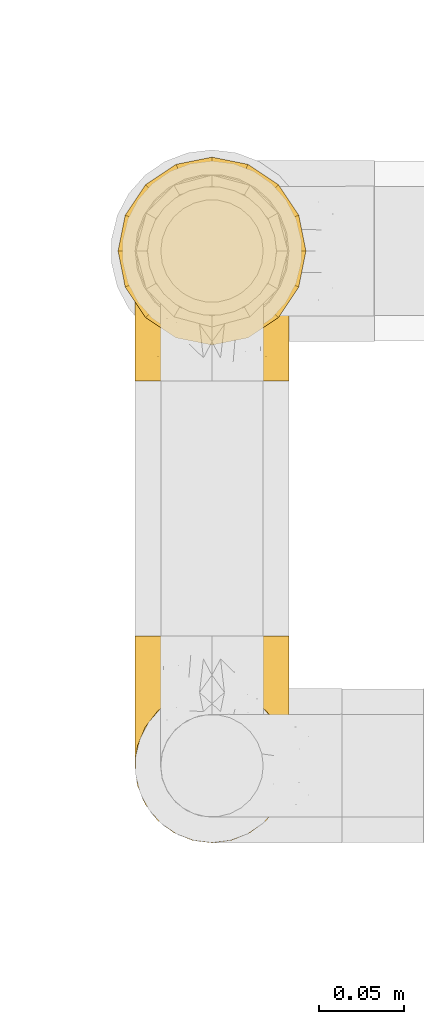
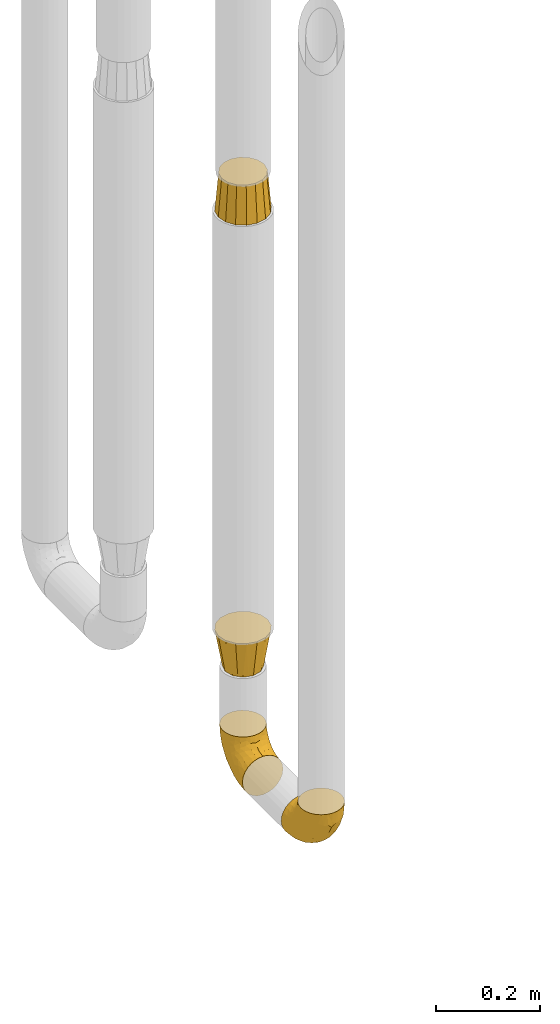
# One storey, part 108 of 827: 4 coverings.
"""IFC2X3 building model written with IfcOpenShell, lengths in millimetres."""

from ifc_helpers import new_model, entity, si_unit, converted_unit, derived_unit, direction, frame, origin, place, context, subcontext, project, spatial, faceted_brep, element, save


model = new_model("IFC2X3")

# Units and contexts
model_context = context("Model", 3, precision=0.01, world=origin(), true_north=direction((6.12303176911189e-17, 1.0)))
body_context = subcontext(model_context, "Body", "Model", "MODEL_VIEW")
ifc_project = project(units=[si_unit("LENGTHUNIT", "METRE", prefix="MILLI"), si_unit("AREAUNIT", "SQUARE_METRE"), si_unit("VOLUMEUNIT", "CUBIC_METRE"), converted_unit("PLANEANGLEUNIT", "DEGREE", entity("IfcRatioMeasure", 0.0174532925199433), si_unit("PLANEANGLEUNIT", "RADIAN"), dimensions=[0, 0, 0, 0, 0, 0, 0]), si_unit("MASSUNIT", "GRAM", prefix="KILO"), derived_unit("MASSDENSITYUNIT", [(si_unit("MASSUNIT", "GRAM", prefix="KILO"), 1), (si_unit("LENGTHUNIT", "METRE"), -3)]), derived_unit("MOMENTOFINERTIAUNIT", [(si_unit("LENGTHUNIT", "METRE"), 4)]), si_unit("TIMEUNIT", "SECOND"), si_unit("FREQUENCYUNIT", "HERTZ"), si_unit("THERMODYNAMICTEMPERATUREUNIT", "DEGREE_CELSIUS"), derived_unit("THERMALTRANSMITTANCEUNIT", [(si_unit("MASSUNIT", "GRAM", prefix="KILO"), 1), (si_unit("THERMODYNAMICTEMPERATUREUNIT", "KELVIN"), -1), (si_unit("TIMEUNIT", "SECOND"), -3)]), derived_unit("VOLUMETRICFLOWRATEUNIT", [(si_unit("LENGTHUNIT", "METRE"), 3), (si_unit("TIMEUNIT", "SECOND"), -1)]), derived_unit("MASSFLOWRATEUNIT", [(si_unit("MASSUNIT", "GRAM", prefix="KILO"), 1), (si_unit("TIMEUNIT", "SECOND"), -1)]), derived_unit("ROTATIONALFREQUENCYUNIT", [(si_unit("TIMEUNIT", "SECOND"), -1)]), si_unit("ELECTRICCURRENTUNIT", "AMPERE"), si_unit("ELECTRICVOLTAGEUNIT", "VOLT"), si_unit("POWERUNIT", "WATT"), si_unit("FORCEUNIT", "NEWTON", prefix="KILO"), si_unit("ILLUMINANCEUNIT", "LUX"), si_unit("LUMINOUSFLUXUNIT", "LUMEN"), si_unit("LUMINOUSINTENSITYUNIT", "CANDELA"), derived_unit("USERDEFINED", [(si_unit("MASSUNIT", "GRAM", prefix="KILO"), -1), (si_unit("LENGTHUNIT", "METRE"), -2), (si_unit("TIMEUNIT", "SECOND"), 3), (si_unit("LUMINOUSFLUXUNIT", "LUMEN"), 1)]), derived_unit("LINEARVELOCITYUNIT", [(si_unit("LENGTHUNIT", "METRE"), 1), (si_unit("TIMEUNIT", "SECOND"), -1)]), si_unit("PRESSUREUNIT", "PASCAL"), derived_unit("USERDEFINED", [(si_unit("LENGTHUNIT", "METRE"), -2), (si_unit("MASSUNIT", "GRAM", prefix="KILO"), 1), (si_unit("TIMEUNIT", "SECOND"), -2)]), derived_unit("LINEARFORCEUNIT", [(si_unit("MASSUNIT", "GRAM", prefix="KILO"), 1), (si_unit("LENGTHUNIT", "METRE"), 1), (si_unit("TIMEUNIT", "SECOND"), -2), (si_unit("LENGTHUNIT", "METRE"), -1)]), derived_unit("PLANARFORCEUNIT", [(si_unit("MASSUNIT", "GRAM", prefix="KILO"), 1), (si_unit("LENGTHUNIT", "METRE"), 1), (si_unit("TIMEUNIT", "SECOND"), -2), (si_unit("LENGTHUNIT", "METRE"), -2)])], contexts=[model_context])

# Site, building, storey
site_placement = place(None, origin())
site = spatial("IfcSite", under=ifc_project, at=site_placement, CompositionType="ELEMENT")
building_placement = place(site_placement, origin())
building = spatial("IfcBuilding", under=site, at=building_placement, CompositionType="ELEMENT")
storey_placement = place(building_placement, frame((0.0, 0.0, 28200.0)))
storey = spatial("IfcBuildingStorey", under=building, at=storey_placement, Name="08", CompositionType="ELEMENT", Elevation=28200.0)

# Coverings
covering_1_placement = place(storey_placement, frame((21053.55, 10451.58, 311.51)))
element("IfcCovering", 1, at=covering_1_placement, inside=storey, Name=":ADSK_", ObjectType=":ADSK_", PredefinedType="INSULATION", context=body_context, shape_type="Brep", body=[
    faceted_brep([(90.76, 122.75, 36.69), (87.42, 122.75, 27.15), (82.04, 122.75, 18.59), (74.89, 122.75, 11.44), (66.33, 122.75, 6.06), (56.79, 122.75, 2.73), (46.75, 122.75, 1.6), (36.69, 122.75, 2.73), (27.15, 122.75, 6.07), (18.59, 122.75, 11.45), (11.44, 122.75, 18.6), (6.06, 122.75, 27.16), (2.73, 122.75, 36.7), (1.6, 122.75, 46.75), (2.73, 122.75, 56.8), (6.07, 122.75, 66.34), (11.45, 122.75, 74.9), (18.6, 122.75, 82.05), (27.16, 122.75, 87.43), (36.7, 122.75, 90.76), (46.75, 122.75, 91.9), (56.8, 122.75, 90.76), (66.34, 122.75, 87.42), (74.9, 122.75, 82.04), (82.05, 122.75, 74.89), (87.43, 122.75, 66.33), (90.76, 122.75, 56.79), (91.9, 122.75, 46.75), (35.06, 90.36, 122.75), (24.17, 85.85, 122.75), (14.82, 78.67, 122.75), (7.64, 69.32, 122.75), (3.13, 58.43, 122.75), (1.6, 46.75, 122.75), (3.13, 35.06, 122.75), (7.64, 24.17, 122.75), (14.82, 14.82, 122.75), (24.17, 7.64, 122.75), (35.06, 3.13, 122.75), (46.75, 1.6, 122.75), (58.43, 3.13, 122.75), (69.32, 7.64, 122.75), (78.67, 14.82, 122.75), (85.85, 24.17, 122.75), (90.36, 35.06, 122.75), (91.9, 46.75, 122.75), (90.36, 58.43, 122.75), (85.85, 69.32, 122.75), (78.67, 78.67, 122.75), (69.32, 85.85, 122.75), (58.43, 90.36, 122.75), (46.75, 91.9, 122.75), (46.75, 51.54, 24.73), (55.2, 47.17, 29.08), (46.75, 38.13, 38.13), (46.75, 7.52, 85.31), (54.53, 5.85, 93.59), (46.75, 5.11, 100.54), (59.63, 19.2, 63.54), (62.07, 38.98, 38.98), (71.86, 35.02, 50.71), (62.65, 8.21, 93.33), (71.33, 19.28, 75.2), (72.93, 12.19, 100.46), (91.2, 101.39, 41.6), (86.31, 34.43, 80.86), (80.89, 20.95, 94.87), (79.49, 30.74, 67.96), (90.68, 72.93, 52.16), (86.84, 56.64, 52.1), (87.38, 80.81, 36.74), (76.87, 93.43, 17.11), (83.73, 100.76, 23.24), (81.03, 74.27, 29.18), (91.9, 93.66, 52.53), (91.9, 81.33, 60.77), (91.9, 69.01, 69.01), (91.03, 40.87, 100.68), (87.58, 29.38, 103.79), (56.52, 67.05, 16.37), (46.75, 85.31, 7.52), (60.4, 93.68, 7.31), (91.9, 52.53, 93.66), (91.9, 50.71, 102.83), (91.9, 48.88, 112.01), (67.87, 72.77, 18.17), (90.35, 51.21, 71.97), (69.57, 101.18, 9.83), (46.75, 100.54, 5.11), (79.91, 48.74, 45.97), (91.9, 112.01, 48.88), (91.9, 102.83, 50.71), (74.99, 73.88, 22.83), (46.75, 24.73, 51.54), (91.9, 60.77, 81.33), (88.53, 103.08, 31.74), (72.65, 54.8, 32.48), (46.75, 16.13, 68.42), (62.97, 55.92, 25.33), (46.75, 68.42, 16.13), (66.2, 104.98, 92.29), (56.6, 108.58, 94.12), (59.89, 98.21, 100.97), (90.95, 61.56, 95.91), (90.22, 60.69, 107.9), (76.64, 100.0, 87.24), (71.58, 95.88, 95.46), (79.99, 90.81, 90.41), (89.54, 84.88, 74.17), (89.97, 73.29, 83.77), (81.32, 113.4, 76.72), (74.56, 109.8, 84.44), (84.15, 102.13, 76.42), (90.37, 67.29, 90.07), (87.82, 70.34, 99.69), (90.98, 95.15, 61.74), (90.96, 105.49, 58.16), (85.14, 71.5, 112.6), (58.11, 92.87, 110.45), (46.75, 96.03, 107.32), (78.39, 81.34, 108.48), (88.22, 107.44, 66.63), (66.06, 88.36, 115.23), (68.6, 90.43, 105.79), (63.78, 114.37, 89.6), (88.42, 98.41, 69.39), (90.61, 88.73, 66.99), (83.8, 76.89, 102.31), (77.98, 86.08, 99.54), (91.22, 112.64, 55.27), (83.46, 94.21, 82.03), (46.75, 112.22, 94.71), (46.75, 107.32, 96.03), (84.66, 79.95, 94.11), (86.33, 84.51, 84.21), (46.75, 101.67, 101.67), (46.75, 94.71, 112.22), (15.1, 81.34, 108.48), (9.69, 76.89, 102.31), (15.52, 86.08, 99.54), (8.83, 79.96, 94.11), (35.39, 92.87, 110.46), (12.18, 113.41, 76.74), (1.6, 102.83, 50.71), (2.53, 105.5, 58.17), (2.27, 112.64, 55.27), (36.9, 108.58, 94.12), (27.31, 104.98, 92.3), (33.62, 98.2, 100.98), (5.07, 98.4, 69.41), (9.36, 102.13, 76.44), (5.27, 107.44, 66.65), (27.43, 88.36, 115.24), (1.6, 50.71, 102.83), (1.6, 48.88, 112.01), (10.05, 94.22, 82.05), (16.87, 100.01, 87.25), (8.35, 71.5, 112.6), (3.27, 60.69, 107.9), (1.6, 52.53, 93.66), (21.94, 95.89, 95.48), (29.72, 114.37, 89.6), (1.6, 81.33, 60.77), (1.6, 69.01, 69.01), (3.96, 84.88, 74.17), (1.6, 112.01, 48.88), (18.95, 109.8, 84.45), (2.54, 61.56, 95.91), (3.12, 67.29, 90.07), (1.6, 60.77, 81.33), (2.51, 95.14, 61.75), (3.52, 73.29, 83.77), (7.17, 84.53, 84.21), (1.6, 93.66, 52.53), (13.52, 90.82, 90.42), (2.88, 88.73, 67.0), (5.67, 70.34, 99.69), (24.89, 90.43, 105.8), (12.6, 20.95, 94.87), (7.18, 34.43, 80.86), (14.0, 30.74, 67.95), (22.16, 19.29, 75.17), (21.61, 35.07, 50.65), (3.14, 51.21, 71.97), (6.65, 56.67, 52.08), (20.82, 54.85, 32.46), (31.41, 38.98, 38.98), (5.91, 29.38, 103.79), (2.46, 40.87, 100.68), (33.87, 19.2, 63.54), (30.84, 8.21, 93.32), (38.96, 5.85, 93.59), (20.56, 12.19, 100.44), (2.81, 72.93, 52.17), (6.1, 80.83, 36.75), (2.29, 101.39, 41.61), (33.08, 93.69, 7.31), (16.61, 93.43, 17.12), (36.96, 67.04, 16.37), (9.75, 100.76, 23.26), (25.61, 72.78, 18.17), (30.5, 55.93, 25.33), (23.91, 101.18, 9.84), (12.45, 74.27, 29.19), (18.49, 73.89, 22.84), (4.96, 103.09, 31.75), (13.56, 48.78, 45.96), (38.28, 47.19, 29.07)], [[[0, 1, 2, 3, 4, 5, 6, 7, 8, 9, 10, 11, 12, 13, 14, 15, 16, 17, 18, 19, 20, 21, 22, 23, 24, 25, 26, 27]], [[28, 29, 30, 31, 32, 33, 34, 35, 36, 37, 38, 39, 40, 41, 42, 43, 44, 45, 46, 47, 48, 49, 50, 51]], [[52, 53, 54]], [[55, 56, 57]], [[58, 59, 60]], [[61, 62, 63]], [[27, 64, 0]], [[65, 66, 67]], [[41, 40, 61]], [[68, 69, 70]], [[66, 43, 42]], [[63, 42, 41]], [[71, 72, 73]], [[72, 2, 1]], [[68, 74, 75, 76]], [[45, 44, 77]], [[43, 78, 44]], [[79, 80, 81]], [[77, 82, 83, 84, 45]], [[79, 81, 85]], [[71, 2, 72]], [[65, 86, 77]], [[4, 81, 5]], [[66, 65, 78]], [[4, 3, 87]], [[81, 88, 5]], [[63, 66, 42]], [[68, 70, 64]], [[67, 60, 89]], [[71, 3, 2]], [[64, 27, 90, 91, 74]], [[92, 71, 73]], [[40, 57, 56]], [[59, 93, 54]], [[86, 76, 94, 82]], [[1, 0, 95]], [[58, 62, 61]], [[60, 96, 89]], [[85, 81, 87]], [[56, 97, 58]], [[65, 67, 69]], [[87, 81, 4]], [[67, 89, 69]], [[61, 63, 41]], [[95, 72, 1]], [[73, 72, 70]], [[69, 73, 70]], [[73, 89, 96]], [[3, 71, 87]], [[85, 87, 71]], [[58, 61, 56]], [[59, 58, 93]], [[76, 86, 68]], [[69, 89, 73]], [[68, 86, 69]], [[65, 69, 86]], [[68, 64, 74]], [[95, 64, 70]], [[98, 79, 85]], [[79, 52, 99, 80]], [[66, 62, 67]], [[62, 58, 60]], [[62, 60, 67]], [[59, 98, 96]], [[59, 96, 60]], [[96, 85, 92]], [[88, 81, 80]], [[88, 6, 5]], [[66, 63, 62]], [[64, 95, 0]], [[72, 95, 70]], [[77, 44, 78]], [[86, 82, 77]], [[40, 39, 57]], [[96, 98, 85]], [[40, 56, 61]], [[66, 78, 43]], [[77, 78, 65]], [[79, 98, 53]], [[96, 92, 73]], [[85, 71, 92]], [[97, 56, 55]], [[97, 93, 58]], [[53, 98, 59]], [[54, 53, 59]], [[79, 53, 52]], [[100, 101, 102]], [[46, 45, 84, 83]], [[103, 104, 82]], [[82, 104, 83]], [[105, 106, 107]], [[108, 109, 76]], [[110, 111, 112]], [[103, 113, 114]], [[115, 74, 116]], [[48, 47, 117]], [[118, 102, 119]], [[49, 48, 120]], [[74, 91, 116]], [[116, 121, 115]], [[49, 122, 50]], [[123, 106, 102]], [[124, 111, 22]], [[125, 126, 115]], [[23, 22, 111]], [[24, 110, 121]], [[120, 127, 128]], [[90, 26, 129]], [[27, 26, 90]], [[121, 125, 115]], [[24, 121, 25]], [[130, 105, 107]], [[129, 25, 116]], [[21, 20, 131]], [[120, 123, 122]], [[112, 105, 130]], [[50, 118, 51]], [[21, 124, 22]], [[101, 131, 132]], [[117, 120, 48]], [[24, 23, 110]], [[127, 114, 133]], [[75, 108, 76]], [[107, 134, 130]], [[133, 114, 113]], [[129, 116, 91]], [[25, 121, 116]], [[121, 112, 125]], [[75, 74, 115]], [[101, 135, 102]], [[131, 101, 21]], [[101, 100, 124]], [[128, 127, 133]], [[119, 136, 51, 118]], [[104, 47, 46]], [[83, 104, 46]], [[117, 104, 114]], [[101, 124, 21]], [[111, 124, 100]], [[102, 118, 123]], [[133, 134, 107]], [[111, 110, 23]], [[114, 104, 103]], [[94, 76, 109]], [[121, 110, 112]], [[122, 118, 50]], [[134, 109, 108]], [[133, 107, 128]], [[112, 108, 125]], [[126, 125, 108]], [[108, 75, 126]], [[75, 115, 126]], [[109, 134, 133]], [[130, 108, 112]], [[108, 130, 134]], [[105, 112, 111]], [[111, 100, 105]], [[106, 105, 100]], [[102, 106, 100]], [[128, 106, 123]], [[90, 129, 91]], [[25, 129, 26]], [[104, 117, 47]], [[117, 114, 127]], [[82, 94, 103]], [[113, 94, 109]], [[94, 113, 103]], [[133, 113, 109]], [[106, 128, 107]], [[123, 120, 128]], [[120, 122, 49]], [[118, 122, 123]], [[135, 101, 132]], [[135, 119, 102]], [[117, 127, 120]], [[30, 29, 137]], [[138, 139, 140]], [[51, 136, 119, 141]], [[142, 17, 16]], [[143, 144, 145]], [[146, 147, 148]], [[149, 150, 151]], [[152, 29, 28]], [[33, 32, 153, 154]], [[150, 155, 156]], [[157, 31, 30]], [[153, 158, 159]], [[29, 152, 137]], [[148, 141, 119]], [[156, 160, 147]], [[148, 135, 146]], [[137, 138, 157]], [[19, 161, 146]], [[162, 163, 164]], [[14, 13, 165]], [[153, 32, 158]], [[147, 161, 166]], [[18, 17, 166]], [[167, 168, 169]], [[166, 150, 156]], [[151, 150, 142]], [[151, 170, 149]], [[151, 16, 15]], [[171, 140, 172]], [[165, 143, 145]], [[173, 170, 144]], [[142, 166, 17]], [[19, 131, 20]], [[144, 170, 151]], [[18, 161, 19]], [[173, 144, 143]], [[140, 139, 174]], [[171, 164, 163]], [[164, 172, 155]], [[151, 15, 144]], [[145, 15, 14]], [[173, 162, 170]], [[149, 175, 164]], [[19, 146, 131]], [[132, 131, 146]], [[160, 148, 147]], [[159, 158, 167]], [[135, 132, 146]], [[158, 32, 31]], [[157, 158, 31]], [[167, 158, 176]], [[166, 161, 18]], [[146, 161, 147]], [[148, 177, 141]], [[171, 168, 140]], [[171, 163, 169]], [[151, 142, 16]], [[166, 142, 150]], [[152, 141, 177]], [[51, 141, 28]], [[138, 140, 176]], [[172, 140, 174]], [[175, 149, 170]], [[164, 150, 149]], [[170, 162, 175]], [[162, 164, 175]], [[155, 172, 174]], [[171, 172, 164]], [[155, 174, 156]], [[164, 155, 150]], [[160, 156, 174]], [[147, 166, 156]], [[139, 160, 174]], [[148, 160, 177]], [[15, 145, 144]], [[165, 145, 14]], [[137, 157, 30]], [[158, 157, 176]], [[168, 167, 176]], [[169, 159, 167]], [[140, 168, 176]], [[169, 168, 171]], [[137, 177, 139]], [[160, 139, 177]], [[141, 152, 28]], [[137, 152, 177]], [[148, 119, 135]], [[157, 138, 176]], [[139, 138, 137]], [[178, 179, 180]], [[181, 180, 182]], [[179, 183, 184]], [[185, 186, 182]], [[187, 188, 179]], [[188, 33, 154, 153, 159]], [[181, 189, 190]], [[35, 34, 187]], [[191, 38, 190]], [[192, 178, 181]], [[179, 184, 180]], [[192, 190, 37]], [[37, 190, 38]], [[36, 35, 178]], [[54, 93, 186]], [[35, 187, 178]], [[193, 194, 184]], [[195, 173, 143, 165, 13]], [[195, 193, 173]], [[193, 163, 162, 173]], [[13, 12, 195]], [[8, 7, 196]], [[9, 197, 10]], [[198, 80, 99, 52]], [[196, 7, 88]], [[197, 199, 10]], [[182, 189, 181]], [[200, 198, 201]], [[200, 196, 198]], [[9, 8, 202]], [[194, 199, 203]], [[192, 37, 36]], [[80, 196, 88]], [[183, 159, 169, 163]], [[188, 34, 33]], [[202, 200, 197]], [[185, 203, 204]], [[202, 8, 196]], [[10, 199, 11]], [[12, 11, 205]], [[38, 191, 57]], [[189, 97, 191]], [[203, 199, 197]], [[205, 199, 194]], [[204, 203, 197]], [[184, 203, 206]], [[200, 202, 196]], [[197, 9, 202]], [[207, 54, 186]], [[97, 55, 191]], [[194, 203, 184]], [[183, 163, 193]], [[184, 206, 180]], [[183, 193, 184]], [[205, 195, 12]], [[193, 195, 194]], [[80, 198, 196]], [[207, 186, 201]], [[182, 180, 206]], [[181, 178, 180]], [[185, 182, 206]], [[182, 186, 189]], [[203, 185, 206]], [[185, 200, 201]], [[7, 6, 88]], [[178, 192, 36]], [[190, 192, 181]], [[199, 205, 11]], [[195, 205, 194]], [[159, 183, 188]], [[179, 188, 183]], [[57, 191, 55]], [[57, 39, 38]], [[189, 191, 190]], [[188, 187, 34]], [[178, 187, 179]], [[186, 93, 189]], [[197, 200, 204]], [[185, 204, 200]], [[189, 93, 97]], [[207, 198, 52]], [[185, 201, 186]], [[198, 207, 201]], [[54, 207, 52]]]),
])
covering_2_placement = place(storey_placement, frame((21053.55, 10722.05, 311.51)))
element("IfcCovering", 2, at=covering_2_placement, inside=storey, Name=":ADSK_", ObjectType=":ADSK_", PredefinedType="INSULATION", context=body_context, shape_type="Brep", body=[
    faceted_brep([(90.76, 87.65, 122.75), (87.42, 97.19, 122.75), (82.04, 105.75, 122.75), (74.89, 112.9, 122.75), (66.33, 118.28, 122.75), (56.79, 121.61, 122.75), (46.75, 122.75, 122.75), (36.69, 121.61, 122.75), (27.15, 118.27, 122.75), (18.59, 112.89, 122.75), (11.44, 105.74, 122.75), (6.06, 97.18, 122.75), (2.73, 87.64, 122.75), (1.6, 77.6, 122.75), (2.73, 67.54, 122.75), (6.07, 58.0, 122.75), (11.45, 49.44, 122.75), (18.6, 42.29, 122.75), (27.16, 36.91, 122.75), (36.7, 33.58, 122.75), (46.75, 32.45, 122.75), (56.8, 33.58, 122.75), (66.34, 36.92, 122.75), (74.9, 42.3, 122.75), (82.05, 49.45, 122.75), (87.43, 58.01, 122.75), (90.76, 67.55, 122.75), (91.9, 77.6, 122.75), (35.06, 1.6, 90.36), (24.17, 1.6, 85.85), (14.82, 1.6, 78.67), (7.64, 1.6, 69.32), (3.13, 1.6, 58.43), (1.6, 1.6, 46.75), (3.13, 1.6, 35.06), (7.64, 1.6, 24.17), (14.82, 1.6, 14.82), (24.17, 1.6, 7.64), (35.06, 1.6, 3.13), (46.75, 1.6, 1.6), (58.43, 1.6, 3.13), (69.32, 1.6, 7.64), (78.67, 1.6, 14.82), (85.85, 1.6, 24.17), (90.36, 1.6, 35.06), (91.9, 1.6, 46.75), (90.36, 1.6, 58.43), (85.85, 1.6, 69.32), (78.67, 1.6, 78.67), (69.32, 1.6, 85.85), (58.43, 1.6, 90.36), (46.75, 1.6, 91.9), (46.75, 99.61, 51.54), (55.2, 95.26, 47.17), (46.75, 86.21, 38.13), (46.75, 39.03, 7.52), (54.53, 30.75, 5.85), (46.75, 23.8, 5.11), (59.63, 60.8, 19.2), (62.07, 85.37, 38.98), (71.86, 73.64, 35.02), (62.65, 31.01, 8.21), (71.33, 49.14, 19.28), (72.93, 23.88, 12.19), (91.2, 82.74, 101.39), (86.31, 43.48, 34.43), (80.89, 29.47, 20.95), (79.49, 56.38, 30.74), (90.68, 72.18, 72.93), (86.84, 72.24, 56.64), (87.38, 87.6, 80.81), (76.87, 107.24, 93.43), (83.73, 101.1, 100.76), (81.03, 95.16, 74.27), (91.9, 71.81, 93.66), (91.9, 63.57, 81.33), (91.9, 55.34, 69.01), (91.03, 23.66, 40.87), (87.58, 20.55, 29.38), (56.52, 107.97, 67.05), (46.75, 116.82, 85.31), (60.4, 117.03, 93.68), (91.9, 30.68, 52.53), (91.9, 21.51, 50.71), (91.9, 12.33, 48.88), (67.87, 106.17, 72.77), (90.35, 52.37, 51.21), (69.57, 114.51, 101.18), (46.75, 119.23, 100.54), (79.91, 78.37, 48.74), (91.9, 75.46, 112.01), (91.9, 73.63, 102.83), (74.99, 101.51, 73.88), (46.75, 72.81, 24.73), (91.9, 43.01, 60.77), (88.53, 92.6, 103.08), (72.65, 91.86, 54.8), (46.75, 55.92, 16.13), (62.97, 99.01, 55.92), (46.75, 108.21, 68.42), (66.2, 32.05, 104.98), (56.6, 30.22, 108.58), (59.89, 23.37, 98.21), (90.95, 28.43, 61.56), (90.22, 16.44, 60.69), (76.64, 37.1, 100.0), (71.58, 28.88, 95.88), (79.99, 33.93, 90.81), (89.54, 50.17, 84.88), (89.97, 40.57, 73.29), (81.32, 47.62, 113.4), (74.56, 39.9, 109.8), (84.15, 47.92, 102.13), (90.37, 34.27, 67.29), (87.82, 24.65, 70.34), (90.98, 62.6, 95.15), (90.96, 66.18, 105.49), (85.14, 11.74, 71.5), (58.11, 13.89, 92.87), (46.75, 17.02, 96.03), (78.39, 15.86, 81.34), (88.22, 57.71, 107.44), (66.06, 9.11, 88.36), (68.6, 18.55, 90.43), (63.78, 34.74, 114.37), (88.42, 54.95, 98.41), (90.61, 57.35, 88.73), (83.8, 22.03, 76.89), (77.98, 24.8, 86.08), (91.22, 69.07, 112.64), (83.46, 42.31, 94.21), (46.75, 29.63, 112.22), (46.75, 28.31, 107.32), (84.66, 30.23, 79.95), (86.33, 40.13, 84.51), (46.75, 22.67, 101.67), (46.75, 12.12, 94.71), (15.1, 15.86, 81.34), (9.69, 22.03, 76.89), (15.52, 24.8, 86.08), (8.83, 30.23, 79.96), (35.39, 13.88, 92.87), (12.18, 47.61, 113.41), (1.6, 73.63, 102.83), (2.53, 66.17, 105.5), (2.27, 69.07, 112.64), (36.9, 30.22, 108.58), (27.31, 32.04, 104.98), (33.62, 23.36, 98.2), (5.07, 54.93, 98.4), (9.36, 47.91, 102.13), (5.27, 57.69, 107.44), (27.43, 9.1, 88.36), (1.6, 21.51, 50.71), (1.6, 12.33, 48.88), (10.05, 42.29, 94.22), (16.87, 37.09, 100.01), (8.35, 11.74, 71.5), (3.27, 16.44, 60.69), (1.6, 30.68, 52.53), (21.94, 28.86, 95.89), (29.72, 34.74, 114.37), (1.6, 63.57, 81.33), (1.6, 55.34, 69.01), (3.96, 50.17, 84.88), (1.6, 75.46, 112.01), (18.95, 39.89, 109.8), (2.54, 28.43, 61.56), (3.12, 34.27, 67.29), (1.6, 43.01, 60.77), (2.51, 62.59, 95.14), (3.52, 40.57, 73.29), (7.17, 40.13, 84.53), (1.6, 71.81, 93.66), (13.52, 33.92, 90.82), (2.88, 57.34, 88.73), (5.67, 24.65, 70.34), (24.89, 18.54, 90.43), (12.6, 29.47, 20.95), (7.18, 43.48, 34.43), (14.0, 56.4, 30.74), (22.16, 49.17, 19.29), (21.61, 73.69, 35.07), (3.14, 52.37, 51.21), (6.65, 72.26, 56.67), (20.82, 91.88, 54.85), (31.41, 85.36, 38.98), (5.91, 20.55, 29.38), (2.46, 23.66, 40.87), (33.87, 60.8, 19.2), (30.84, 31.02, 8.21), (38.96, 30.75, 5.85), (20.56, 23.9, 12.19), (2.81, 72.17, 72.93), (6.1, 87.59, 80.83), (2.29, 82.74, 101.39), (33.08, 117.03, 93.69), (16.61, 107.23, 93.43), (36.96, 107.97, 67.04), (9.75, 101.08, 100.76), (25.61, 106.17, 72.78), (30.5, 99.01, 55.93), (23.91, 114.5, 101.18), (12.45, 95.15, 74.27), (18.49, 101.5, 73.89), (4.96, 92.59, 103.09), (13.56, 78.38, 48.78), (38.28, 95.27, 47.19)], [[[0, 1, 2, 3, 4, 5, 6, 7, 8, 9, 10, 11, 12, 13, 14, 15, 16, 17, 18, 19, 20, 21, 22, 23, 24, 25, 26, 27]], [[28, 29, 30, 31, 32, 33, 34, 35, 36, 37, 38, 39, 40, 41, 42, 43, 44, 45, 46, 47, 48, 49, 50, 51]], [[52, 53, 54]], [[55, 56, 57]], [[58, 59, 60]], [[61, 62, 63]], [[27, 64, 0]], [[65, 66, 67]], [[41, 40, 61]], [[68, 69, 70]], [[66, 43, 42]], [[63, 42, 41]], [[71, 72, 73]], [[72, 2, 1]], [[68, 74, 75, 76]], [[45, 44, 77]], [[43, 78, 44]], [[79, 80, 81]], [[77, 82, 83, 84, 45]], [[79, 81, 85]], [[71, 2, 72]], [[65, 86, 77]], [[4, 81, 5]], [[66, 65, 78]], [[4, 3, 87]], [[81, 88, 5]], [[63, 66, 42]], [[68, 70, 64]], [[67, 60, 89]], [[71, 3, 2]], [[64, 27, 90, 91, 74]], [[92, 71, 73]], [[40, 57, 56]], [[59, 93, 54]], [[86, 76, 94, 82]], [[1, 0, 95]], [[58, 62, 61]], [[60, 96, 89]], [[85, 81, 87]], [[56, 97, 58]], [[65, 67, 69]], [[87, 81, 4]], [[67, 89, 69]], [[61, 63, 41]], [[95, 72, 1]], [[73, 72, 70]], [[69, 73, 70]], [[73, 89, 96]], [[3, 71, 87]], [[85, 87, 71]], [[58, 61, 56]], [[59, 58, 93]], [[76, 86, 68]], [[69, 89, 73]], [[68, 86, 69]], [[65, 69, 86]], [[68, 64, 74]], [[95, 64, 70]], [[98, 79, 85]], [[79, 52, 99, 80]], [[66, 62, 67]], [[62, 58, 60]], [[62, 60, 67]], [[59, 98, 96]], [[59, 96, 60]], [[96, 85, 92]], [[88, 81, 80]], [[88, 6, 5]], [[66, 63, 62]], [[64, 95, 0]], [[72, 95, 70]], [[77, 44, 78]], [[86, 82, 77]], [[40, 39, 57]], [[96, 98, 85]], [[40, 56, 61]], [[66, 78, 43]], [[77, 78, 65]], [[79, 98, 53]], [[96, 92, 73]], [[85, 71, 92]], [[97, 56, 55]], [[97, 93, 58]], [[53, 98, 59]], [[54, 53, 59]], [[79, 53, 52]], [[100, 101, 102]], [[46, 45, 84, 83]], [[103, 104, 82]], [[82, 104, 83]], [[105, 106, 107]], [[108, 109, 76]], [[110, 111, 112]], [[103, 113, 114]], [[115, 74, 116]], [[48, 47, 117]], [[118, 102, 119]], [[49, 48, 120]], [[74, 91, 116]], [[116, 121, 115]], [[49, 122, 50]], [[123, 106, 102]], [[124, 111, 22]], [[125, 126, 115]], [[23, 22, 111]], [[24, 110, 121]], [[120, 127, 128]], [[90, 26, 129]], [[27, 26, 90]], [[121, 125, 115]], [[24, 121, 25]], [[130, 105, 107]], [[129, 25, 116]], [[21, 20, 131]], [[120, 123, 122]], [[112, 105, 130]], [[50, 118, 51]], [[21, 124, 22]], [[101, 131, 132]], [[117, 120, 48]], [[24, 23, 110]], [[127, 114, 133]], [[75, 108, 76]], [[107, 134, 130]], [[133, 114, 113]], [[129, 116, 91]], [[25, 121, 116]], [[121, 112, 125]], [[75, 74, 115]], [[101, 135, 102]], [[131, 101, 21]], [[101, 100, 124]], [[128, 127, 133]], [[119, 136, 51, 118]], [[104, 47, 46]], [[83, 104, 46]], [[117, 104, 114]], [[101, 124, 21]], [[111, 124, 100]], [[102, 118, 123]], [[133, 134, 107]], [[111, 110, 23]], [[114, 104, 103]], [[94, 76, 109]], [[121, 110, 112]], [[122, 118, 50]], [[134, 109, 108]], [[133, 107, 128]], [[112, 108, 125]], [[126, 125, 108]], [[108, 75, 126]], [[75, 115, 126]], [[109, 134, 133]], [[130, 108, 112]], [[108, 130, 134]], [[105, 112, 111]], [[111, 100, 105]], [[106, 105, 100]], [[102, 106, 100]], [[128, 106, 123]], [[90, 129, 91]], [[25, 129, 26]], [[104, 117, 47]], [[117, 114, 127]], [[82, 94, 103]], [[113, 94, 109]], [[94, 113, 103]], [[133, 113, 109]], [[106, 128, 107]], [[123, 120, 128]], [[120, 122, 49]], [[118, 122, 123]], [[135, 101, 132]], [[135, 119, 102]], [[117, 127, 120]], [[30, 29, 137]], [[138, 139, 140]], [[51, 136, 119, 141]], [[142, 17, 16]], [[143, 144, 145]], [[146, 147, 148]], [[149, 150, 151]], [[152, 29, 28]], [[33, 32, 153, 154]], [[150, 155, 156]], [[157, 31, 30]], [[153, 158, 159]], [[29, 152, 137]], [[148, 141, 119]], [[156, 160, 147]], [[148, 135, 146]], [[137, 138, 157]], [[19, 161, 146]], [[162, 163, 164]], [[14, 13, 165]], [[153, 32, 158]], [[147, 161, 166]], [[18, 17, 166]], [[167, 168, 169]], [[166, 150, 156]], [[151, 150, 142]], [[151, 170, 149]], [[151, 16, 15]], [[171, 140, 172]], [[165, 143, 145]], [[173, 170, 144]], [[142, 166, 17]], [[19, 131, 20]], [[144, 170, 151]], [[18, 161, 19]], [[173, 144, 143]], [[140, 139, 174]], [[171, 164, 163]], [[164, 172, 155]], [[151, 15, 144]], [[145, 15, 14]], [[173, 162, 170]], [[149, 175, 164]], [[19, 146, 131]], [[132, 131, 146]], [[160, 148, 147]], [[159, 158, 167]], [[135, 132, 146]], [[158, 32, 31]], [[157, 158, 31]], [[167, 158, 176]], [[166, 161, 18]], [[146, 161, 147]], [[148, 177, 141]], [[171, 168, 140]], [[171, 163, 169]], [[151, 142, 16]], [[166, 142, 150]], [[152, 141, 177]], [[51, 141, 28]], [[138, 140, 176]], [[172, 140, 174]], [[175, 149, 170]], [[164, 150, 149]], [[170, 162, 175]], [[162, 164, 175]], [[155, 172, 174]], [[171, 172, 164]], [[155, 174, 156]], [[164, 155, 150]], [[160, 156, 174]], [[147, 166, 156]], [[139, 160, 174]], [[148, 160, 177]], [[15, 145, 144]], [[165, 145, 14]], [[137, 157, 30]], [[158, 157, 176]], [[168, 167, 176]], [[169, 159, 167]], [[140, 168, 176]], [[169, 168, 171]], [[137, 177, 139]], [[160, 139, 177]], [[141, 152, 28]], [[137, 152, 177]], [[148, 119, 135]], [[157, 138, 176]], [[139, 138, 137]], [[178, 179, 180]], [[181, 180, 182]], [[179, 183, 184]], [[185, 186, 182]], [[187, 188, 179]], [[188, 33, 154, 153, 159]], [[181, 189, 190]], [[35, 34, 187]], [[191, 38, 190]], [[192, 178, 181]], [[179, 184, 180]], [[192, 190, 37]], [[37, 190, 38]], [[36, 35, 178]], [[54, 93, 186]], [[35, 187, 178]], [[193, 194, 184]], [[195, 173, 143, 165, 13]], [[195, 193, 173]], [[193, 163, 162, 173]], [[13, 12, 195]], [[8, 7, 196]], [[9, 197, 10]], [[198, 80, 99, 52]], [[196, 7, 88]], [[197, 199, 10]], [[182, 189, 181]], [[200, 198, 201]], [[200, 196, 198]], [[9, 8, 202]], [[194, 199, 203]], [[192, 37, 36]], [[80, 196, 88]], [[183, 159, 169, 163]], [[188, 34, 33]], [[202, 200, 197]], [[185, 203, 204]], [[202, 8, 196]], [[10, 199, 11]], [[12, 11, 205]], [[38, 191, 57]], [[189, 97, 191]], [[203, 199, 197]], [[205, 199, 194]], [[204, 203, 197]], [[184, 203, 206]], [[200, 202, 196]], [[197, 9, 202]], [[207, 54, 186]], [[97, 55, 191]], [[194, 203, 184]], [[183, 163, 193]], [[184, 206, 180]], [[183, 193, 184]], [[205, 195, 12]], [[193, 195, 194]], [[80, 198, 196]], [[207, 186, 201]], [[182, 180, 206]], [[181, 178, 180]], [[185, 182, 206]], [[182, 186, 189]], [[203, 185, 206]], [[185, 200, 201]], [[7, 6, 88]], [[178, 192, 36]], [[190, 192, 181]], [[199, 205, 11]], [[195, 205, 194]], [[159, 183, 188]], [[179, 188, 183]], [[57, 191, 55]], [[57, 39, 38]], [[189, 191, 190]], [[188, 187, 34]], [[178, 187, 179]], [[186, 93, 189]], [[197, 200, 204]], [[185, 204, 200]], [[189, 93, 97]], [[207, 198, 52]], [[185, 201, 186]], [[198, 207, 201]], [[54, 207, 52]]]),
])
covering_3_placement = place(storey_placement, frame((21043.7, 10743.05, 571.26)))
element("IfcCovering", 3, at=covering_3_placement, inside=storey, Name=":ADSK_", ObjectType=":ADSK_", PredefinedType="INSULATION", context=body_context, shape_type="Brep", body=[
    faceted_brep([(91.24, 76.6, 0.0), (93.92, 66.6, 0.0), (96.6, 56.6, 0.0), (93.92, 46.6, 0.0), (91.24, 36.6, 0.0), (83.92, 29.27, 0.0), (76.6, 21.95, 0.0), (66.6, 19.27, 0.0), (56.6, 16.6, 0.0), (46.6, 19.27, 0.0), (36.6, 21.95, 0.0), (29.27, 29.27, 0.0), (21.95, 36.6, 0.0), (19.27, 46.6, 0.0), (16.6, 56.6, 0.0), (19.27, 66.6, 0.0), (21.95, 76.6, 0.0), (29.27, 83.92, 0.0), (36.6, 91.24, 0.0), (46.6, 93.92, 0.0), (56.6, 96.6, 0.0), (66.6, 93.92, 0.0), (76.6, 91.24, 0.0), (83.92, 83.92, 0.0), (77.64, 107.41, 89.0), (67.12, 109.5, 89.0), (56.6, 111.6, 89.0), (46.07, 109.5, 89.0), (35.55, 107.41, 89.0), (26.63, 101.45, 89.0), (17.7, 95.49, 89.0), (11.74, 86.56, 89.0), (5.78, 77.64, 89.0), (3.69, 67.12, 89.0), (1.6, 56.6, 89.0), (3.69, 46.07, 89.0), (5.78, 35.55, 89.0), (11.74, 26.63, 89.0), (17.7, 17.7, 89.0), (26.63, 11.74, 89.0), (35.55, 5.78, 89.0), (46.07, 3.69, 89.0), (56.6, 1.6, 89.0), (67.12, 3.69, 89.0), (77.64, 5.78, 89.0), (86.56, 11.74, 89.0), (95.49, 17.7, 89.0), (101.45, 26.63, 89.0), (107.41, 35.55, 89.0), (109.5, 46.07, 89.0), (111.6, 56.6, 89.0), (109.5, 67.12, 89.0), (107.41, 77.64, 89.0), (101.45, 86.56, 89.0), (95.49, 95.49, 89.0), (86.56, 101.45, 89.0)], [[[0, 1, 2, 3, 4, 5, 6, 7, 8, 9, 10, 11, 12, 13, 14, 15, 16, 17, 18, 19, 20, 21, 22, 23]], [[24, 25, 26, 27, 28, 29, 30, 31, 32, 33, 34, 35, 36, 37, 38, 39, 40, 41, 42, 43, 44, 45, 46, 47, 48, 49, 50, 51, 52, 53, 54, 55]], [[35, 34, 14]], [[10, 40, 39]], [[37, 36, 12]], [[37, 12, 11]], [[10, 39, 11]], [[37, 11, 38]], [[41, 40, 9]], [[14, 13, 35]], [[39, 38, 11]], [[8, 41, 9]], [[13, 12, 36]], [[41, 8, 42]], [[40, 10, 9]], [[13, 36, 35]], [[27, 26, 20]], [[16, 32, 31]], [[29, 28, 18]], [[29, 18, 17]], [[16, 31, 17]], [[29, 17, 30]], [[33, 32, 15]], [[20, 19, 27]], [[31, 30, 17]], [[14, 33, 15]], [[19, 18, 28]], [[33, 14, 34]], [[32, 16, 15]], [[19, 28, 27]], [[51, 50, 2]], [[22, 24, 55]], [[53, 52, 0]], [[53, 0, 23]], [[22, 55, 23]], [[53, 23, 54]], [[25, 24, 21]], [[2, 1, 51]], [[55, 54, 23]], [[20, 25, 21]], [[1, 0, 52]], [[25, 20, 26]], [[24, 22, 21]], [[1, 52, 51]], [[43, 42, 8]], [[4, 48, 47]], [[45, 44, 6]], [[45, 6, 5]], [[4, 47, 5]], [[45, 5, 46]], [[49, 48, 3]], [[8, 7, 43]], [[47, 46, 5]], [[2, 49, 3]], [[7, 6, 44]], [[49, 2, 50]], [[48, 4, 3]], [[7, 44, 43]]]),
])
covering_4_placement = place(storey_placement, frame((21043.7, 10743.05, 1643.85)))
element("IfcCovering", 4, at=covering_4_placement, inside=storey, Name=":ADSK_", ObjectType=":ADSK_", PredefinedType="INSULATION", context=body_context, shape_type="Brep", body=[
    faceted_brep([(56.6, 104.1, 89.0), (47.51, 102.29, 89.0), (38.42, 100.48, 89.0), (30.71, 95.33, 89.0), (23.01, 90.18, 89.0), (17.86, 82.48, 89.0), (12.71, 74.77, 89.0), (10.9, 65.68, 89.0), (9.1, 56.6, 89.0), (10.9, 47.51, 89.0), (12.71, 38.42, 89.0), (17.86, 30.71, 89.0), (23.01, 23.01, 89.0), (30.71, 17.86, 89.0), (38.42, 12.71, 89.0), (47.51, 10.9, 89.0), (56.6, 9.1, 89.0), (65.68, 10.9, 89.0), (74.77, 12.71, 89.0), (82.48, 17.86, 89.0), (90.18, 23.01, 89.0), (95.33, 30.71, 89.0), (100.48, 38.42, 89.0), (102.29, 47.51, 89.0), (104.1, 56.6, 89.0), (102.29, 65.68, 89.0), (100.48, 74.77, 89.0), (95.33, 82.48, 89.0), (90.18, 90.18, 89.0), (82.48, 95.33, 89.0), (74.77, 100.48, 89.0), (65.68, 102.29, 89.0), (77.64, 5.78, 0.0), (69.69, 4.2, 0.0), (56.6, 1.6, 0.0), (43.51, 4.2, 0.0), (35.55, 5.78, 0.0), (26.63, 11.74, 0.0), (17.7, 17.7, 0.0), (11.74, 26.63, 0.0), (5.78, 35.55, 0.0), (4.2, 43.51, 0.0), (1.6, 56.6, 0.0), (4.2, 69.69, 0.0), (5.78, 77.64, 0.0), (11.74, 86.56, 0.0), (17.7, 95.49, 0.0), (26.63, 101.45, 0.0), (35.55, 107.41, 0.0), (43.51, 108.99, 0.0), (56.6, 111.6, 0.0), (69.69, 108.99, 0.0), (77.64, 107.41, 0.0), (86.56, 101.45, 0.0), (95.49, 95.49, 0.0), (101.45, 86.56, 0.0), (107.41, 77.64, 0.0), (108.99, 69.69, 0.0), (111.6, 56.6, 0.0), (108.99, 43.51, 0.0), (107.41, 35.55, 0.0), (101.45, 26.63, 0.0), (95.49, 17.7, 0.0), (86.56, 11.74, 0.0)], [[[0, 1, 2, 3, 4, 5, 6, 7, 8, 9, 10, 11, 12, 13, 14, 15, 16, 17, 18, 19, 20, 21, 22, 23, 24, 25, 26, 27, 28, 29, 30, 31]], [[32, 33, 34, 35, 36, 37, 38, 39, 40, 41, 42, 43, 44, 45, 46, 47, 48, 49, 50, 51, 52, 53, 54, 55, 56, 57, 58, 59, 60, 61, 62, 63]], [[6, 44, 43, 42, 8, 7]], [[5, 4, 46, 45, 44, 6]], [[1, 0, 50, 49, 48, 2]], [[4, 3, 2, 48, 47, 46]], [[14, 36, 35, 34, 16, 15]], [[13, 12, 38, 37, 36, 14]], [[9, 8, 42, 41, 40, 10]], [[12, 11, 10, 40, 39, 38]], [[22, 60, 59, 58, 24, 23]], [[21, 20, 62, 61, 60, 22]], [[17, 16, 34, 33, 32, 18]], [[20, 19, 18, 32, 63, 62]], [[30, 52, 51, 50, 0, 31]], [[29, 28, 54, 53, 52, 30]], [[25, 24, 58, 57, 56, 26]], [[28, 27, 26, 56, 55, 54]]]),
])

save(model, "model.ifc")
